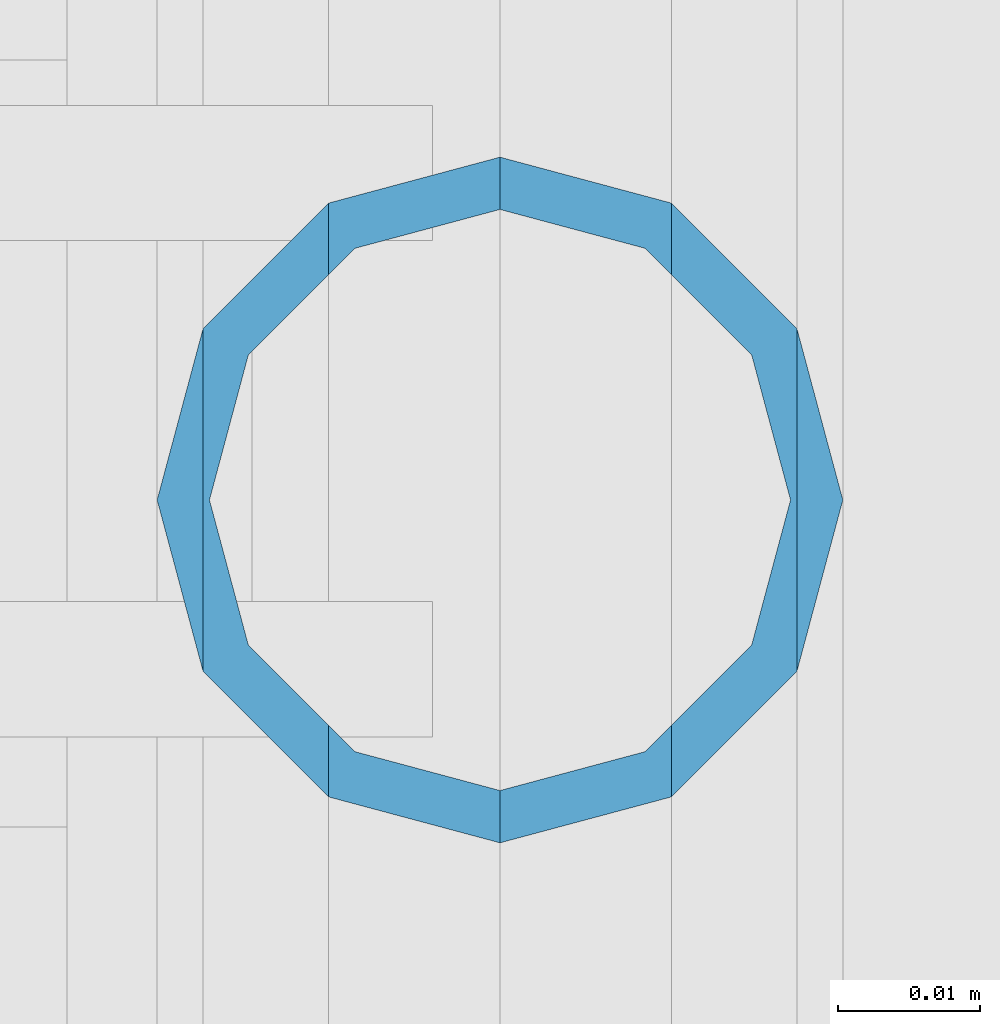
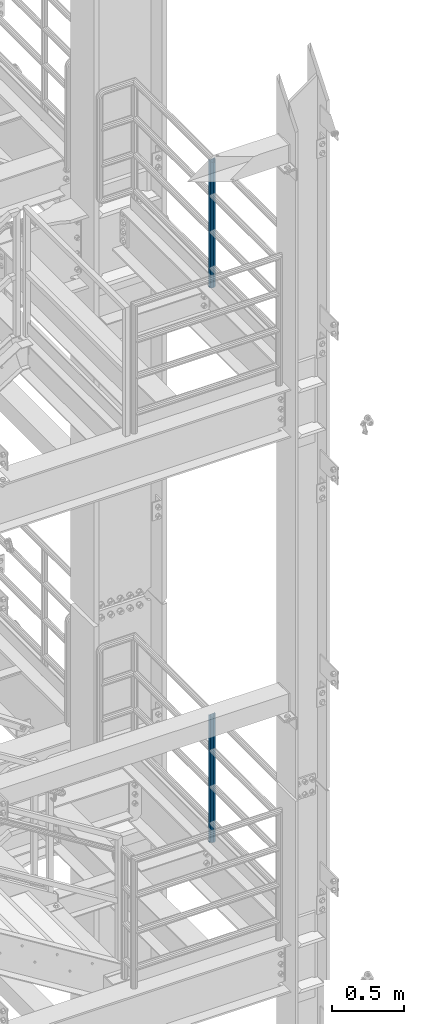
# One storey, part 659 of 1876: 2 columns, 2 elements without a shape of their own.
"""IFC2X3 building model written with IfcOpenShell, lengths in millimetres."""

from ifc_helpers import new_model, si_unit, frame, origin_with_axes, place, context, subcontext, project, spatial, faceted_brep, material, type_object, element, aggregate, save


model = new_model("IFC2X3")

# Units and contexts
model_context = context("Model", 3, precision=1e-05, world=origin_with_axes())
body_context = subcontext(model_context, "Body", "Model", "MODEL_VIEW")
ifc_project = project(units=[si_unit("LENGTHUNIT", "METRE", prefix="MILLI"), si_unit("AREAUNIT", "SQUARE_METRE"), si_unit("VOLUMEUNIT", "CUBIC_METRE"), si_unit("MASSUNIT", "GRAM", prefix="KILO"), si_unit("TIMEUNIT", "SECOND"), si_unit("PLANEANGLEUNIT", "RADIAN"), si_unit("SOLIDANGLEUNIT", "STERADIAN"), si_unit("THERMODYNAMICTEMPERATUREUNIT", "DEGREE_CELSIUS"), si_unit("LUMINOUSINTENSITYUNIT", "LUMEN")], contexts=[model_context])

# Site, building, storey
site_placement = place(None, origin_with_axes())
site = spatial("IfcSite", under=ifc_project, at=site_placement, CompositionType="ELEMENT")
building_placement = place(site_placement, origin_with_axes())
building = spatial("IfcBuilding", under=site, at=building_placement, Name="Undefined", CompositionType="ELEMENT")
storey_placement = place(building_placement, origin_with_axes())
storey = spatial("IfcBuildingStorey", under=building, at=storey_placement, Name="Undefined", CompositionType="ELEMENT", Elevation=0.0)

# Assembly, column
assembly_1_placement = place(storey_placement, origin_with_axes())
assembly_1 = element("IfcElementAssembly", 1, at=assembly_1_placement, inside=storey, Name="RAIL", AssemblyPlace="NOTDEFINED", PredefinedType="RIGID_FRAME")
ifc_material = material()
column_type = type_object("IfcColumnType", Name="PIPE1-1/2SCH40", PredefinedType="NOTDEFINED")
column_1_placement = place(assembly_1_placement, frame((7620.00000000001, -5857.08125, 17983.2), z_axis=(0.0, 1.0, 0.0), x_axis=(0.0, 0.0, 1.0)))
column_1 = element("IfcColumn", 2, at=column_1_placement, type_object=column_type, material=ifc_material, Name="POST", ObjectType="PIPE1-1/2SCH40", context=body_context, shape_type="Brep", body=[
    faceted_brep([(1055.42780700668, -12.0650000000001, 20.8971929933186), (1055.42780700668, -12.0650000000001, 15.8661214311805), (1054.93437856882, -10.2235000000001, 17.7076214311801), (1052.195, 0.0, 20.4470000000001), (1052.195, 0.0, 24.1300000000001), (1054.93437856882, 10.2235000000001, 17.7076214311801), (1055.42780700668, 12.0650000000001, 15.8661214311805), (1055.42780700668, 12.0650000000001, 20.8971929933186), (1076.325, 24.1300000000001, 0.0), (1064.26, 20.8971929933184, 12.0649999999996), (1064.25999999999, 20.8971929933186, -12.0649999999996), (1061.07042843786, 17.7076214311803, 10.2235000000001), (1063.80980700668, 20.4469999999999, 0.0), (1061.07042843786, 17.7076214311803, -10.2235000000001), (1055.42780700668, 12.0650000000001, -15.8661214311805), (1055.42780700667, 12.0649999999996, -20.8971929933186), (1054.93437856882, 10.2235000000001, -17.7076214311801), (1052.195, 0.0, -20.4470000000001), (1052.19499999999, 0.0, -24.1300000000001), (1055.42780700668, -12.0650000000001, -15.8661214311805), (1055.42780700667, -12.0649999999996, -20.8971929933186), (1054.93437856882, -10.2235000000001, -17.7076214311801), (1076.325, -24.1300000000001, 0.0), (1064.25999999999, -20.8971929933186, -12.0649999999996), (1064.26, -20.8971929933184, 12.0649999999996), (1061.07042843786, -17.7076214311803, -10.2235000000001), (1063.80980700668, -20.4469999999999, 0.0), (1061.07042843786, -17.7076214311803, 10.2235000000001), (0.0, -20.8971929933184, -12.0649999999996), (0.0, -12.0650000000001, -20.8971929933186), (-1.45519152283669e-11, 0.0, -24.130000000001), (0.0, 12.0650000000001, -20.8971929933186), (0.0, 20.8971929933184, -12.0649999999996), (0.0, 24.1299999999992, 0.0), (0.0, 20.8971929933184, 12.0649999999996), (0.0, 12.0650000000001, 20.8971929933186), (-1.45519152283669e-11, 0.0, 24.130000000001), (0.0, -12.0650000000001, 20.8971929933186), (0.0, -20.8971929933184, 12.0649999999996), (0.0, -24.1299999999992, 0.0), (0.0, -17.7076214311803, -10.2235000000001), (0.0, -10.2235000000001, -17.7076214311801), (-1.45519152283669e-11, 0.0, -20.4470000000001), (0.0, 10.2235000000001, -17.7076214311801), (0.0, 17.7076214311803, -10.2235000000001), (0.0, 20.4469999999999, 0.0), (0.0, 17.7076214311803, 10.2235000000001), (0.0, 10.2235000000001, 17.7076214311801), (-1.45519152283669e-11, 0.0, 20.4470000000001), (0.0, -10.2235000000001, 17.7076214311801), (0.0, -17.7076214311803, 10.2235000000001), (0.0, -20.4469999999999, 0.0)], [[[0, 1, 2, 3, 4]], [[4, 3, 5, 6, 7]], [[8, 9, 10]], [[7, 6, 11, 12, 13, 14, 15, 10, 9]], [[16, 17, 18, 15, 14]], [[19, 20, 18, 17, 21]], [[22, 23, 24]], [[24, 23, 20, 19, 25, 26, 27, 1, 0]], [[28, 29, 20, 23]], [[29, 30, 18, 20]], [[30, 31, 15, 18]], [[31, 32, 10, 15]], [[32, 33, 8, 10]], [[33, 34, 9, 8]], [[34, 35, 7, 9]], [[35, 36, 4, 7]], [[36, 37, 0, 4]], [[37, 38, 24, 0]], [[38, 39, 22, 24]], [[39, 28, 23, 22]], [[38, 37, 36, 35, 34, 33, 32, 31, 30, 29, 28, 39], [40, 41, 42, 43, 44, 45, 46, 47, 48, 49, 50, 51]], [[40, 51, 26, 25]], [[21, 41, 40, 25, 19]], [[42, 41, 21, 17]], [[43, 42, 17, 16]], [[44, 43, 16, 14, 13]], [[45, 44, 13, 12]], [[46, 45, 12, 11]], [[5, 47, 46, 11, 6]], [[48, 47, 5, 3]], [[49, 48, 3, 2]], [[50, 49, 2, 1, 27]], [[51, 50, 27, 26]]]),
])
aggregate(assembly_1, [column_1])

assembly_2_placement = place(storey_placement, origin_with_axes())
assembly_2 = element("IfcElementAssembly", 3, at=assembly_2_placement, inside=storey, Name="RAIL", AssemblyPlace="NOTDEFINED", PredefinedType="RIGID_FRAME")
column_2_placement = place(assembly_2_placement, frame((7620.00000000001, -5857.08125, 13309.6), z_axis=(0.0, 1.0, 0.0), x_axis=(0.0, 0.0, 1.0)))
column_2 = element("IfcColumn", 4, at=column_2_placement, type_object=column_type, material=ifc_material, Name="POST", ObjectType="PIPE1-1/2SCH40", context=body_context, shape_type="Brep", body=[
    faceted_brep([(1055.42780700668, -12.0650000000001, 20.8971929933186), (1055.42780700668, -12.0650000000001, 15.8661214311805), (1054.93437856882, -10.2235000000001, 17.7076214311801), (1052.195, 0.0, 20.4470000000001), (1052.195, 0.0, 24.1300000000001), (1054.93437856882, 10.2235000000001, 17.7076214311801), (1055.42780700668, 12.0650000000001, 15.8661214311805), (1055.42780700668, 12.0650000000001, 20.8971929933186), (1076.325, 24.1300000000001, 0.0), (1064.26, 20.8971929933184, 12.0649999999996), (1064.25999999999, 20.8971929933186, -12.0649999999996), (1061.07042843786, 17.7076214311803, 10.2235000000001), (1063.80980700668, 20.4469999999999, 0.0), (1061.07042843786, 17.7076214311803, -10.2235000000001), (1055.42780700668, 12.0650000000001, -15.8661214311805), (1055.42780700667, 12.0649999999996, -20.8971929933186), (1054.93437856882, 10.2235000000001, -17.7076214311801), (1052.195, 0.0, -20.4470000000001), (1052.19499999999, 0.0, -24.1300000000001), (1055.42780700668, -12.0650000000001, -15.8661214311805), (1055.42780700667, -12.0649999999996, -20.8971929933186), (1054.93437856882, -10.2235000000001, -17.7076214311801), (1076.325, -24.1300000000001, 0.0), (1064.25999999999, -20.8971929933186, -12.0649999999996), (1064.26, -20.8971929933184, 12.0649999999996), (1061.07042843786, -17.7076214311803, -10.2235000000001), (1063.80980700668, -20.4469999999999, 0.0), (1061.07042843786, -17.7076214311803, 10.2235000000001), (0.0, -20.8971929933184, -12.0649999999996), (0.0, -12.0650000000001, -20.8971929933186), (-1.45519152283669e-11, 0.0, -24.130000000001), (0.0, 12.0650000000001, -20.8971929933186), (0.0, 20.8971929933184, -12.0649999999996), (0.0, 24.1299999999992, 0.0), (0.0, 20.8971929933184, 12.0649999999996), (0.0, 12.0650000000001, 20.8971929933186), (-1.45519152283669e-11, 0.0, 24.130000000001), (0.0, -12.0650000000001, 20.8971929933186), (0.0, -20.8971929933184, 12.0649999999996), (0.0, -24.1299999999992, 0.0), (0.0, -17.7076214311803, -10.2235000000001), (0.0, -10.2235000000001, -17.7076214311801), (-1.45519152283669e-11, 0.0, -20.4470000000001), (0.0, 10.2235000000001, -17.7076214311801), (0.0, 17.7076214311803, -10.2235000000001), (0.0, 20.4469999999999, 0.0), (0.0, 17.7076214311803, 10.2235000000001), (0.0, 10.2235000000001, 17.7076214311801), (-1.45519152283669e-11, 0.0, 20.4470000000001), (0.0, -10.2235000000001, 17.7076214311801), (0.0, -17.7076214311803, 10.2235000000001), (0.0, -20.4469999999999, 0.0)], [[[0, 1, 2, 3, 4]], [[4, 3, 5, 6, 7]], [[8, 9, 10]], [[7, 6, 11, 12, 13, 14, 15, 10, 9]], [[16, 17, 18, 15, 14]], [[19, 20, 18, 17, 21]], [[22, 23, 24]], [[24, 23, 20, 19, 25, 26, 27, 1, 0]], [[28, 29, 20, 23]], [[29, 30, 18, 20]], [[30, 31, 15, 18]], [[31, 32, 10, 15]], [[32, 33, 8, 10]], [[33, 34, 9, 8]], [[34, 35, 7, 9]], [[35, 36, 4, 7]], [[36, 37, 0, 4]], [[37, 38, 24, 0]], [[38, 39, 22, 24]], [[39, 28, 23, 22]], [[38, 37, 36, 35, 34, 33, 32, 31, 30, 29, 28, 39], [40, 41, 42, 43, 44, 45, 46, 47, 48, 49, 50, 51]], [[40, 51, 26, 25]], [[21, 41, 40, 25, 19]], [[42, 41, 21, 17]], [[43, 42, 17, 16]], [[44, 43, 16, 14, 13]], [[45, 44, 13, 12]], [[46, 45, 12, 11]], [[5, 47, 46, 11, 6]], [[48, 47, 5, 3]], [[49, 48, 3, 2]], [[50, 49, 2, 1, 27]], [[51, 50, 27, 26]]]),
])
aggregate(assembly_2, [column_2])

save(model, "model.ifc")
